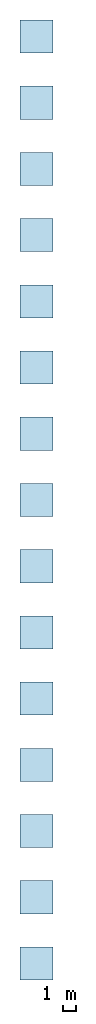
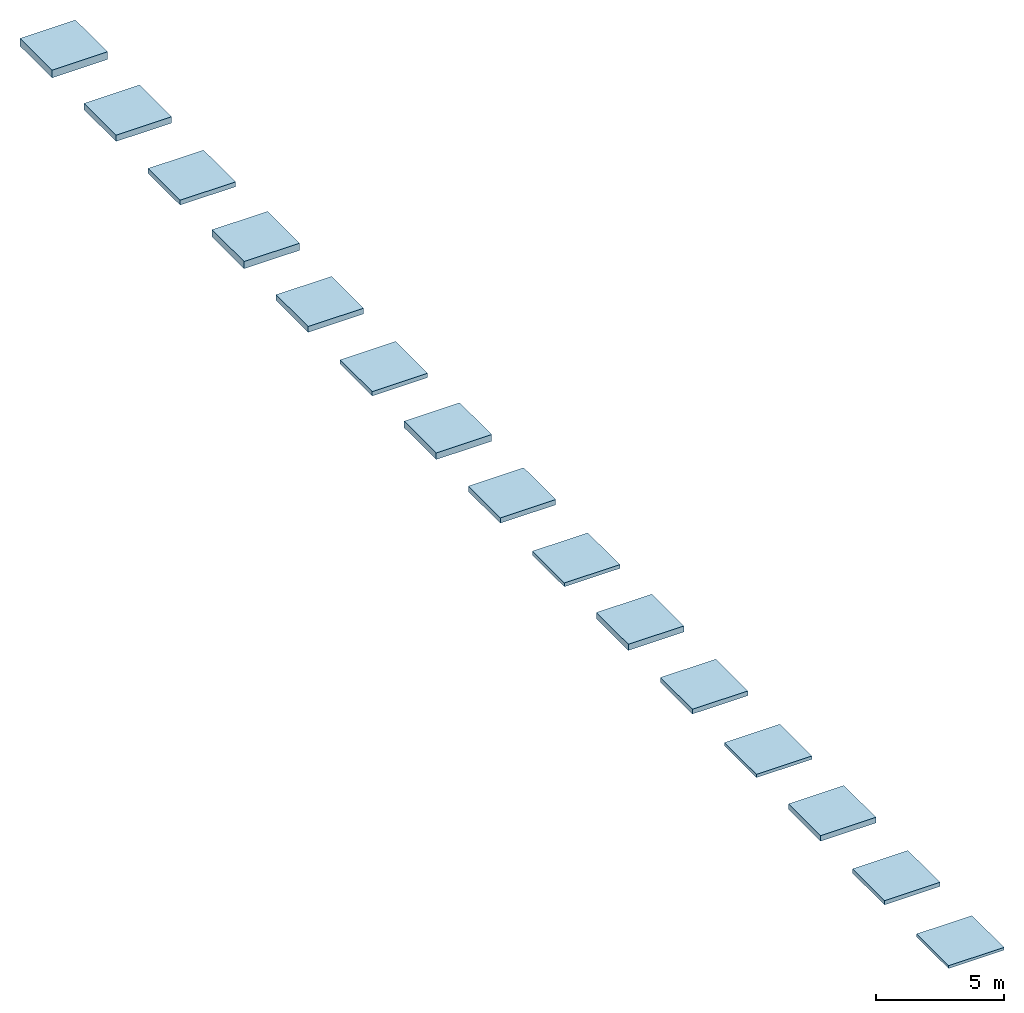
# Not in any storey: 15 slabs.
"""IFC2X3 building model written with IfcOpenShell, lengths in millimetres."""

from ifc_helpers import new_model, si_unit, frame, frame_2d, origin, origin_with_axes, origin_2d, place, context, project, spatial, rectangle, extrude, material, layer, layer_set, layer_usage, type_object, element, save


model = new_model("IFC2X3")

# Units and contexts
model_context = context("Model", 3, precision=1e-05, world=origin())
plan_context = context("Plan", 2, precision=1e-05, world=origin_2d())
ifc_project = project(units=[si_unit("LENGTHUNIT", "METRE", prefix="MILLI"), si_unit("AREAUNIT", "SQUARE_METRE"), si_unit("VOLUMEUNIT", "CUBIC_METRE"), si_unit("SOLIDANGLEUNIT", "STERADIAN"), si_unit("PLANEANGLEUNIT", "RADIAN"), si_unit("MASSUNIT", "GRAM"), si_unit("TIMEUNIT", "SECOND"), si_unit("THERMODYNAMICTEMPERATUREUNIT", "DEGREE_CELSIUS"), si_unit("LUMINOUSINTENSITYUNIT", "LUMEN")], contexts=[model_context, plan_context])

# Site, building
site_placement = place(None, frame((0.0, 0.0, 0.0), z_axis=(0.0, 1.0, 0.0), x_axis=(0.0, 0.0, 1.0)))
site = spatial("IfcSite", under=ifc_project, at=site_placement, CompositionType="ELEMENT")
building_placement = place(site_placement, frame((0.0, 0.0, 0.0), z_axis=(0.0, 1.0, 0.0), x_axis=(0.0, 0.0, 1.0)))
building = spatial("IfcBuilding", under=site, at=building_placement, Name="Default building", CompositionType="ELEMENT")

# Slabs
ifc_material_1 = material()
ifc_layer_1 = layer(ifc_material_1, 130.0, ventilated=False)
ifc_layer_set_1 = layer_set([ifc_layer_1])
ifc_layer_usage_1 = layer_usage(ifc_layer_set_1, "AXIS3", "NEGATIVE", 0.0)
slab_type_1 = type_object("IfcSlabType", PredefinedType="FLOOR", material=ifc_layer_set_1)
slab_1_placement = place(None, origin())
element("IfcSlab", 1, at=slab_1_placement, inside=building, type_object=slab_type_1, material=ifc_layer_usage_1, PredefinedType="FLOOR", context=model_context, shape_type="SweptSolid", body=[
    extrude(rectangle(XDim=2500.0, YDim=2500.0, at=frame_2d((1250.0, 1250.0))), origin_with_axes(), (0.0, 0.0, 1.0), 130.0),
])
ifc_material_2 = material()
ifc_layer_2 = layer(ifc_material_2, 200.0, ventilated=False)
ifc_layer_set_2 = layer_set([ifc_layer_2])
ifc_layer_usage_2 = layer_usage(ifc_layer_set_2, "AXIS3", "NEGATIVE", 0.0)
slab_type_2 = type_object("IfcSlabType", PredefinedType="FLOOR", material=ifc_layer_set_2)
slab_2_placement = place(None, frame((0.0, 5000.0, 0.0)))
element("IfcSlab", 2, at=slab_2_placement, inside=building, type_object=slab_type_2, material=ifc_layer_usage_2, PredefinedType="FLOOR", context=model_context, shape_type="SweptSolid", body=[
    extrude(rectangle(XDim=2500.0, YDim=2500.0, at=frame_2d((1250.0, 1250.0))), origin_with_axes(), (0.0, 0.0, 1.0), 200.0),
])
ifc_material_3 = material()
ifc_layer_3 = layer(ifc_material_3, 265.0, ventilated=False)
ifc_layer_set_3 = layer_set([ifc_layer_3])
ifc_layer_usage_3 = layer_usage(ifc_layer_set_3, "AXIS3", "NEGATIVE", 0.0)
slab_type_3 = type_object("IfcSlabType", PredefinedType="FLOOR", material=ifc_layer_set_3)
slab_3_placement = place(None, frame((0.0, 10000.0, 0.0)))
element("IfcSlab", 3, at=slab_3_placement, inside=building, type_object=slab_type_3, material=ifc_layer_usage_3, PredefinedType="FLOOR", context=model_context, shape_type="SweptSolid", body=[
    extrude(rectangle(XDim=2500.0, YDim=2500.0, at=frame_2d((1250.0, 1250.0))), origin_with_axes(), (0.0, 0.0, 1.0), 265.0),
])
ifc_material_4 = material()
ifc_layer_4 = layer(ifc_material_4, 155.0, ventilated=False)
ifc_layer_set_4 = layer_set([ifc_layer_4])
ifc_layer_usage_4 = layer_usage(ifc_layer_set_4, "AXIS3", "NEGATIVE", 0.0)
slab_type_4 = type_object("IfcSlabType", PredefinedType="FLOOR", material=ifc_layer_set_4)
slab_4_placement = place(None, frame((0.0, 15000.0, 0.0)))
element("IfcSlab", 4, at=slab_4_placement, inside=building, type_object=slab_type_4, material=ifc_layer_usage_4, PredefinedType="FLOOR", context=model_context, shape_type="SweptSolid", body=[
    extrude(rectangle(XDim=2500.0, YDim=2500.0, at=frame_2d((1250.0, 1250.0))), origin_with_axes(), (0.0, 0.0, 1.0), 155.0),
])
ifc_material_5 = material()
ifc_layer_5 = layer(ifc_material_5, 225.0, ventilated=False)
ifc_layer_set_5 = layer_set([ifc_layer_5])
ifc_layer_usage_5 = layer_usage(ifc_layer_set_5, "AXIS3", "NEGATIVE", 0.0)
slab_type_5 = type_object("IfcSlabType", PredefinedType="FLOOR", material=ifc_layer_set_5)
slab_5_placement = place(None, frame((0.0, 20000.0, 0.0)))
element("IfcSlab", 5, at=slab_5_placement, inside=building, type_object=slab_type_5, material=ifc_layer_usage_5, PredefinedType="FLOOR", context=model_context, shape_type="SweptSolid", body=[
    extrude(rectangle(XDim=2500.0, YDim=2500.0, at=frame_2d((1250.0, 1250.0))), origin_with_axes(), (0.0, 0.0, 1.0), 225.0),
])
ifc_material_6 = material()
ifc_layer_6 = layer(ifc_material_6, 290.0, ventilated=False)
ifc_layer_set_6 = layer_set([ifc_layer_6])
ifc_layer_usage_6 = layer_usage(ifc_layer_set_6, "AXIS3", "NEGATIVE", 0.0)
slab_type_6 = type_object("IfcSlabType", PredefinedType="FLOOR", material=ifc_layer_set_6)
slab_6_placement = place(None, frame((0.0, 25000.0, 0.0)))
element("IfcSlab", 6, at=slab_6_placement, inside=building, type_object=slab_type_6, material=ifc_layer_usage_6, PredefinedType="FLOOR", context=model_context, shape_type="SweptSolid", body=[
    extrude(rectangle(XDim=2500.0, YDim=2500.0, at=frame_2d((1250.0, 1250.0))), origin_with_axes(), (0.0, 0.0, 1.0), 290.0),
])
ifc_material_7 = material()
ifc_layer_7 = layer(ifc_material_7, 180.0, ventilated=False)
ifc_layer_set_7 = layer_set([ifc_layer_7])
ifc_layer_usage_7 = layer_usage(ifc_layer_set_7, "AXIS3", "NEGATIVE", 0.0)
slab_type_7 = type_object("IfcSlabType", PredefinedType="FLOOR", material=ifc_layer_set_7)
slab_7_placement = place(None, frame((0.0, 30000.0, 0.0)))
element("IfcSlab", 7, at=slab_7_placement, inside=building, type_object=slab_type_7, material=ifc_layer_usage_7, PredefinedType="FLOOR", context=model_context, shape_type="SweptSolid", body=[
    extrude(rectangle(XDim=2500.0, YDim=2500.0, at=frame_2d((1250.0, 1250.0))), origin_with_axes(), (0.0, 0.0, 1.0), 180.0),
])
ifc_material_8 = material()
ifc_layer_8 = layer(ifc_material_8, 250.0, ventilated=False)
ifc_layer_set_8 = layer_set([ifc_layer_8])
ifc_layer_usage_8 = layer_usage(ifc_layer_set_8, "AXIS3", "NEGATIVE", 0.0)
slab_type_8 = type_object("IfcSlabType", PredefinedType="FLOOR", material=ifc_layer_set_8)
slab_8_placement = place(None, frame((0.0, 35000.0, 0.0)))
element("IfcSlab", 8, at=slab_8_placement, inside=building, type_object=slab_type_8, material=ifc_layer_usage_8, PredefinedType="FLOOR", context=model_context, shape_type="SweptSolid", body=[
    extrude(rectangle(XDim=2500.0, YDim=2500.0, at=frame_2d((1250.0, 1250.0))), origin_with_axes(), (0.0, 0.0, 1.0), 250.0),
])
ifc_material_9 = material()
ifc_layer_9 = layer(ifc_material_9, 315.0, ventilated=False)
ifc_layer_set_9 = layer_set([ifc_layer_9])
ifc_layer_usage_9 = layer_usage(ifc_layer_set_9, "AXIS3", "NEGATIVE", 0.0)
slab_type_9 = type_object("IfcSlabType", PredefinedType="FLOOR", material=ifc_layer_set_9)
slab_9_placement = place(None, frame((0.0, 40000.0, 0.0)))
element("IfcSlab", 9, at=slab_9_placement, inside=building, type_object=slab_type_9, material=ifc_layer_usage_9, PredefinedType="FLOOR", context=model_context, shape_type="SweptSolid", body=[
    extrude(rectangle(XDim=2500.0, YDim=2500.0, at=frame_2d((1250.0, 1250.0))), origin_with_axes(), (0.0, 0.0, 1.0), 315.0),
])
ifc_material_10 = material()
ifc_layer_10 = layer(ifc_material_10, 205.0, ventilated=False)
ifc_layer_set_10 = layer_set([ifc_layer_10])
ifc_layer_usage_10 = layer_usage(ifc_layer_set_10, "AXIS3", "NEGATIVE", 0.0)
slab_type_10 = type_object("IfcSlabType", PredefinedType="FLOOR", material=ifc_layer_set_10)
slab_10_placement = place(None, frame((0.0, 45000.0, 0.0)))
element("IfcSlab", 10, at=slab_10_placement, inside=building, type_object=slab_type_10, material=ifc_layer_usage_10, PredefinedType="FLOOR", context=model_context, shape_type="SweptSolid", body=[
    extrude(rectangle(XDim=2500.0, YDim=2500.0, at=frame_2d((1250.0, 1250.0))), origin_with_axes(), (0.0, 0.0, 1.0), 205.0),
])
ifc_material_11 = material()
ifc_layer_11 = layer(ifc_material_11, 275.0, ventilated=False)
ifc_layer_set_11 = layer_set([ifc_layer_11])
ifc_layer_usage_11 = layer_usage(ifc_layer_set_11, "AXIS3", "NEGATIVE", 0.0)
slab_type_11 = type_object("IfcSlabType", PredefinedType="FLOOR", material=ifc_layer_set_11)
slab_11_placement = place(None, frame((0.0, 50000.0, 0.0)))
element("IfcSlab", 11, at=slab_11_placement, inside=building, type_object=slab_type_11, material=ifc_layer_usage_11, PredefinedType="FLOOR", context=model_context, shape_type="SweptSolid", body=[
    extrude(rectangle(XDim=2500.0, YDim=2500.0, at=frame_2d((1250.0, 1250.0))), origin_with_axes(), (0.0, 0.0, 1.0), 275.0),
])
ifc_material_12 = material()
ifc_layer_12 = layer(ifc_material_12, 340.0, ventilated=False)
ifc_layer_set_12 = layer_set([ifc_layer_12])
ifc_layer_usage_12 = layer_usage(ifc_layer_set_12, "AXIS3", "NEGATIVE", 0.0)
slab_type_12 = type_object("IfcSlabType", PredefinedType="FLOOR", material=ifc_layer_set_12)
slab_12_placement = place(None, frame((0.0, 55000.0, 0.0)))
element("IfcSlab", 12, at=slab_12_placement, inside=building, type_object=slab_type_12, material=ifc_layer_usage_12, PredefinedType="FLOOR", context=model_context, shape_type="SweptSolid", body=[
    extrude(rectangle(XDim=2500.0, YDim=2500.0, at=frame_2d((1250.0, 1250.0))), origin_with_axes(), (0.0, 0.0, 1.0), 340.0),
])
ifc_material_13 = material()
ifc_layer_13 = layer(ifc_material_13, 230.0, ventilated=False)
ifc_layer_set_13 = layer_set([ifc_layer_13])
ifc_layer_usage_13 = layer_usage(ifc_layer_set_13, "AXIS3", "NEGATIVE", 0.0)
slab_type_13 = type_object("IfcSlabType", PredefinedType="FLOOR", material=ifc_layer_set_13)
slab_13_placement = place(None, frame((0.0, 60000.0, 0.0)))
element("IfcSlab", 13, at=slab_13_placement, inside=building, type_object=slab_type_13, material=ifc_layer_usage_13, PredefinedType="FLOOR", context=model_context, shape_type="SweptSolid", body=[
    extrude(rectangle(XDim=2500.0, YDim=2500.0, at=frame_2d((1250.0, 1250.0))), origin_with_axes(), (0.0, 0.0, 1.0), 230.0),
])
ifc_material_14 = material()
ifc_layer_14 = layer(ifc_material_14, 300.0, ventilated=False)
ifc_layer_set_14 = layer_set([ifc_layer_14])
ifc_layer_usage_14 = layer_usage(ifc_layer_set_14, "AXIS3", "NEGATIVE", 0.0)
slab_type_14 = type_object("IfcSlabType", PredefinedType="FLOOR", material=ifc_layer_set_14)
slab_14_placement = place(None, frame((0.0, 65000.0, 0.0)))
element("IfcSlab", 14, at=slab_14_placement, inside=building, type_object=slab_type_14, material=ifc_layer_usage_14, PredefinedType="FLOOR", context=model_context, shape_type="SweptSolid", body=[
    extrude(rectangle(XDim=2500.0, YDim=2500.0, at=frame_2d((1250.0, 1250.0))), origin_with_axes(), (0.0, 0.0, 1.0), 300.0),
])
ifc_material_15 = material()
ifc_layer_15 = layer(ifc_material_15, 365.0, ventilated=False)
ifc_layer_set_15 = layer_set([ifc_layer_15])
ifc_layer_usage_15 = layer_usage(ifc_layer_set_15, "AXIS3", "NEGATIVE", 0.0)
slab_type_15 = type_object("IfcSlabType", PredefinedType="FLOOR", material=ifc_layer_set_15)
slab_15_placement = place(None, frame((0.0, 70000.0, 0.0)))
element("IfcSlab", 15, at=slab_15_placement, inside=building, type_object=slab_type_15, material=ifc_layer_usage_15, PredefinedType="FLOOR", context=model_context, shape_type="SweptSolid", body=[
    extrude(rectangle(XDim=2500.0, YDim=2500.0, at=frame_2d((1250.0, 1250.0))), origin_with_axes(), (0.0, 0.0, 1.0), 365.0),
])

save(model, "model.ifc")
